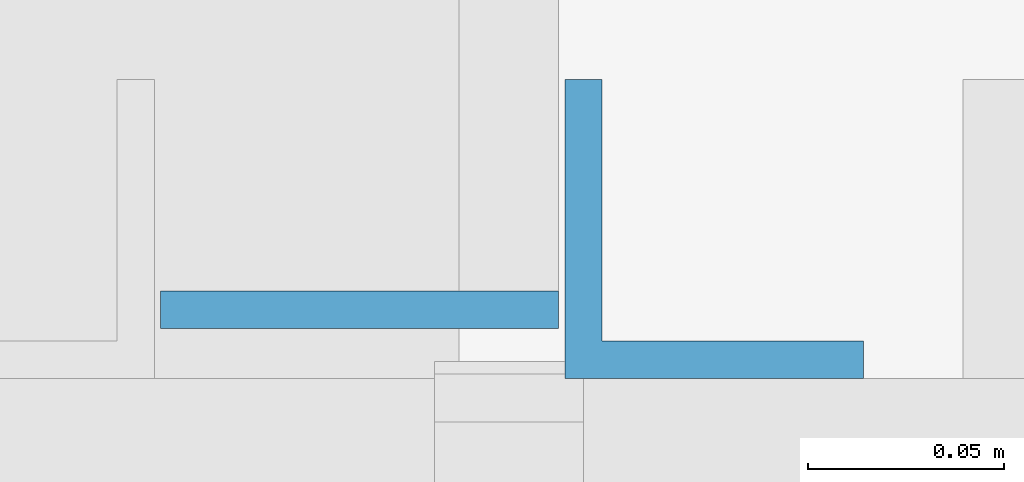
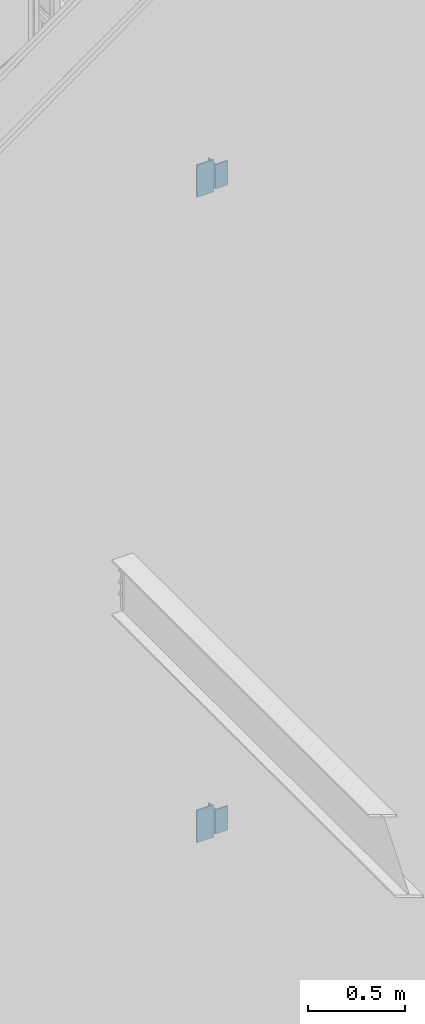
# One storey, part 570 of 1179: 4 columns, 4 elements without a shape of their own.
"""IFC2X3 building model written with IfcOpenShell, lengths in millimetres."""

import ifcopenshell
import ifcopenshell.guid

model = None  # the IFC model being written
_history = None  # IfcOwnerHistory: only IFC2X3 demands one
_inside = {}  # id of a spatial element -> (the spatial element, [elements in it])
_under = {}  # id of a project, library or spatial element -> (it, [spatial elements below it])
_declared = {}  # id of a project -> (the project, [libraries it declares])
_typed = {}  # id of a type object -> (the type object, [elements of that type])
_made_of = {}  # id of a material, layer set ... -> (it, [elements and type objects made of it])


def new_model(schema):
    """Start an empty IFC model of exactly this schema.

    Asked for "IFC4X3", IfcOpenShell would pick the latest addendum, in which some entities
    have other attributes; the version numbers below select the first issue.
    IFC2X3 requires an IfcOwnerHistory on every rooted entity: one is made here for all.
    """
    global model, _history
    if schema == "IFC4X3":
        model = ifcopenshell.file(schema_version=(4, 3, 0, 0))
    else:
        model = ifcopenshell.file(schema=schema)
    _inside.clear()
    _under.clear()
    _declared.clear()
    _typed.clear()
    _made_of.clear()
    _history = None
    if model.schema == "IFC2X3":
        org = make("IfcOrganization", Name="unknown")
        user = make(
            "IfcPersonAndOrganization",
            ThePerson=make("IfcPerson", FamilyName="unknown"),
            TheOrganization=org,
        )
        app = make(
            "IfcApplication",
            ApplicationDeveloper=org,
            Version="unknown",
            ApplicationFullName="unknown",
            ApplicationIdentifier="unknown",
        )
        _history = make(
            "IfcOwnerHistory",
            OwningUser=user,
            OwningApplication=app,
            ChangeAction="ADDED",
            CreationDate=0,
        )
    return model


def make(cls, **values):
    """One entity of the class cls with the attributes given. An attribute that is None is left unset."""
    return model.create_entity(
        cls, **{name: value for name, value in values.items() if value is not None}
    )


def rooted(cls, **values):
    """An entity with a GlobalId (a new one), such as an element, a storey or a relation."""
    return make(cls, GlobalId=ifcopenshell.guid.new(), OwnerHistory=_history, **values)


def si_unit(unit_type, name, prefix=None):
    """IfcSIUnit, for example si_unit("LENGTHUNIT", "METRE", prefix="MILLI")."""
    return make("IfcSIUnit", UnitType=unit_type, Prefix=prefix, Name=name)


def assignment(units):
    """IfcUnitAssignment: the units of a project."""
    return None if units is None else make("IfcUnitAssignment", Units=units)


def point(xyz):
    """IfcCartesianPoint."""
    return None if xyz is None else make("IfcCartesianPoint", Coordinates=xyz)


def direction(xyz):
    """IfcDirection."""
    return None if xyz is None else make("IfcDirection", DirectionRatios=xyz)


def frame(location, z_axis=None, x_axis=None):
    """IfcAxis2Placement3D, a coordinate frame: its origin and axes. An axis left out is left unset."""
    return make(
        "IfcAxis2Placement3D",
        Location=point(location),
        Axis=direction(z_axis),
        RefDirection=direction(x_axis),
    )


def origin_with_axes():
    """The frame at (0, 0, 0) with the z axis (0, 0, 1) and the x axis (1, 0, 0) written out."""
    return frame((0.0, 0.0, 0.0), z_axis=(0.0, 0.0, 1.0), x_axis=(1.0, 0.0, 0.0))


def place(relative_to, where):
    """IfcLocalPlacement: puts the frame where relative to a parent placement (None: the world)."""
    return make(
        "IfcLocalPlacement", PlacementRelTo=relative_to, RelativePlacement=where
    )


def context(
    kind, dimensions, precision=None, world=None, true_north=None, identifier=None
):
    """IfcGeometricRepresentationContext, for example the 3D "Model" context."""
    return make(
        "IfcGeometricRepresentationContext",
        ContextIdentifier=identifier,
        ContextType=kind,
        CoordinateSpaceDimension=dimensions,
        Precision=precision,
        WorldCoordinateSystem=world,
        TrueNorth=true_north,
    )


def subcontext(parent, identifier, kind, view, scale=None):
    """IfcGeometricRepresentationSubContext, for example "Body" below "Model"."""
    return make(
        "IfcGeometricRepresentationSubContext",
        ContextIdentifier=identifier,
        ContextType=kind,
        ParentContext=parent,
        TargetScale=scale,
        TargetView=view,
    )


def project(units=None, contexts=None):
    """IfcProject with its units and contexts."""
    return rooted(
        "IfcProject",
        Name="project",
        RepresentationContexts=contexts,
        UnitsInContext=assignment(units),
    )


def spatial(cls, under=None, at=None, **own):
    """A site, building, storey or space (cls), placed at a placement, below another one or the project."""
    s = rooted(cls, ObjectPlacement=at, **own)
    if under is not None:
        _under.setdefault(under.id(), (under, []))[1].append(s)
    return s


def faces_of(points, faces, orient=None, outer=None):
    """IfcFace entities. A face is a list of loops; a loop is a list of indices into points, from 0.

    orient and outer hold one flag for each loop. By default every Orientation is true, the
    first loop of a face is its IfcFaceOuterBound and the others are IfcFaceBound.
    """
    made = []
    for i, loops in enumerate(faces):
        bounds = []
        for j, loop in enumerate(loops):
            is_outer = j == 0 if outer is None else outer[i][j]
            bounds.append(
                make(
                    "IfcFaceOuterBound" if is_outer else "IfcFaceBound",
                    Bound=make("IfcPolyLoop", Polygon=[points[k] for k in loop]),
                    Orientation=True if orient is None else orient[i][j],
                )
            )
        made.append(make("IfcFace", Bounds=bounds))
    return made


def faceted_brep(points, faces, orient=None, outer=None, voids=None):
    """IfcFacetedBrep: a solid bounded by flat faces; with voids (closed shells), ...WithVoids."""
    shared = [point(p) for p in points]
    hull = make("IfcClosedShell", CfsFaces=faces_of(shared, faces, orient, outer))
    if voids is None:
        return make("IfcFacetedBrep", Outer=hull)
    return make(
        "IfcFacetedBrepWithVoids",
        Outer=hull,
        Voids=[
            make(cls, CfsFaces=faces_of(shared, fs, o, b)) for cls, fs, o, b in voids
        ],
    )


def shape(context_of_items, identifier, shape_type, items):
    """IfcShapeRepresentation: the items that make up one representation, for example the "Body"."""
    return make(
        "IfcShapeRepresentation",
        ContextOfItems=context_of_items,
        RepresentationIdentifier=identifier,
        RepresentationType=shape_type,
        Items=items,
    )


def material(Name=None, Category=None):
    """IfcMaterial."""
    return make("IfcMaterial", Name=Name, Category=Category)


def made_of(thing, what):
    """Note that an element or type object is made of a material, layer set ...; save() writes the relation."""
    if what is not None:
        _made_of.setdefault(what.id(), (what, []))[1].append(thing)
    return thing


def type_object(cls, material=None, **own):
    """A type object (cls), such as IfcWallType, which elements share."""
    return made_of(rooted(cls, **own), material)


def element(
    cls,
    number,
    at=None,
    inside=None,
    cuts=None,
    type_object=None,
    material=None,
    context=None,
    identifier="Body",
    shape_type=None,
    held_by="IfcProductDefinitionShape",
    body=None,
    shapes=None,
    **own,
):
    """One element of the class cls, such as IfcWall. Its Tag is "e" and its number.

    at: its placement. inside: the storey or other place that contains it. cuts: it is an
    opening in that element (IfcRelVoidsElement). A single representation is given by context,
    identifier, shape_type and body (its items); several are given by shapes. held_by: the class
    of the entity that holds the representations. save() writes the other relations.
    """
    e = rooted(cls, Tag="e%d" % number, ObjectPlacement=at, **own)
    if body is not None:
        shapes = [shape(context, identifier, shape_type, body)]
    if shapes is not None:
        e.Representation = make(held_by, Representations=shapes)
    if inside is not None:
        _inside.setdefault(inside.id(), (inside, []))[1].append(e)
    if cuts is not None:
        rooted(
            "IfcRelVoidsElement", RelatingBuildingElement=cuts, RelatedOpeningElement=e
        )
    if type_object is not None:
        _typed.setdefault(type_object.id(), (type_object, []))[1].append(e)
    return made_of(e, material)


def aggregate(whole, parts):
    """IfcRelAggregates: a whole, such as a stair, and the parts it consists of."""
    return rooted("IfcRelAggregates", RelatingObject=whole, RelatedObjects=parts)


def save(model, path):
    """Write the relations noted so far, then the file.

    IfcRelAggregates (storeys below a building ...), IfcRelContainedInSpatialStructure (elements
    in a storey), IfcRelDefinesByType, IfcRelAssociatesMaterial and IfcRelDeclares: one each for
    every whole, place, type object, material and project.
    """
    for whole, parts in _under.values():
        aggregate(whole, parts)
    for where, things in _inside.values():
        rooted(
            "IfcRelContainedInSpatialStructure",
            RelatedElements=things,
            RelatingStructure=where,
        )
    for kind, things in _typed.values():
        rooted("IfcRelDefinesByType", RelatedObjects=things, RelatingType=kind)
    for what, things in _made_of.values():
        rooted("IfcRelAssociatesMaterial", RelatedObjects=things, RelatingMaterial=what)
    for by, libraries in _declared.values():
        rooted("IfcRelDeclares", RelatingContext=by, RelatedDefinitions=libraries)
    model.write(path)


model = new_model("IFC2X3")

# Units and contexts
model_context = context("Model", 3, precision=1e-05, world=origin_with_axes())
body_context = subcontext(model_context, "Body", "Model", "MODEL_VIEW")
ifc_project = project(units=[si_unit("LENGTHUNIT", "METRE", prefix="MILLI"), si_unit("AREAUNIT", "SQUARE_METRE"), si_unit("VOLUMEUNIT", "CUBIC_METRE"), si_unit("MASSUNIT", "GRAM", prefix="KILO"), si_unit("TIMEUNIT", "SECOND"), si_unit("PLANEANGLEUNIT", "RADIAN"), si_unit("SOLIDANGLEUNIT", "STERADIAN"), si_unit("THERMODYNAMICTEMPERATUREUNIT", "DEGREE_CELSIUS"), si_unit("LUMINOUSINTENSITYUNIT", "LUMEN")], contexts=[model_context])

# Site, building, storey
site_placement = place(None, origin_with_axes())
site = spatial("IfcSite", under=ifc_project, at=site_placement, CompositionType="ELEMENT")
building_placement = place(site_placement, origin_with_axes())
building = spatial("IfcBuilding", under=site, at=building_placement, Name="Undefined", CompositionType="ELEMENT")
storey_placement = place(building_placement, origin_with_axes())
storey = spatial("IfcBuildingStorey", under=building, at=storey_placement, Name="Undefined", CompositionType="ELEMENT", Elevation=0.0)

# Assembly, column
assembly_1_placement = place(storey_placement, origin_with_axes())
assembly_1 = element("IfcElementAssembly", 1, at=assembly_1_placement, inside=storey, Name="BEAM", AssemblyPlace="NOTDEFINED", PredefinedType="RIGID_FRAME")
ifc_material = material(Name="STEEL/A36")
column_type_1 = type_object("IfcColumnType", PredefinedType="NOTDEFINED")
column_1_placement = place(assembly_1_placement, frame((23018.7499999835, 38225.4124999754, 5934.67000099707), z_axis=(1.0, 0.0, 0.0), x_axis=(0.0, 0.0, 1.0)))
column_1 = element("IfcColumn", 2, at=column_1_placement, type_object=column_type_1, material=ifc_material, Name="PLATE", context=body_context, shape_type="Brep", body=[
    faceted_brep([(0.0, 4.76249999999982, -50.7999999999993), (0.0, 4.76249999999982, 50.7999999999993), (203.2, 4.76249999999709, 50.7999999999993), (203.2, 4.76249999999709, -50.7999999999993), (0.0, -4.76249999999982, 50.7999999999993), (203.2, -4.76249999999709, 50.7999999999993), (0.0, -4.76249999999982, -50.7999999999993), (203.2, -4.76249999999709, -50.7999999999993)], [[[0, 1, 2, 3]], [[1, 4, 5, 2]], [[4, 6, 7, 5]], [[6, 0, 3, 7]], [[5, 7, 3, 2]], [[6, 4, 1, 0]]]),
])
aggregate(assembly_1, [column_1])

assembly_2_placement = place(storey_placement, origin_with_axes())
assembly_2 = element("IfcElementAssembly", 3, at=assembly_2_placement, inside=storey, Name="BEAM", AssemblyPlace="NOTDEFINED", PredefinedType="RIGID_FRAME")
column_2_placement = place(assembly_2_placement, frame((23018.7500003381, 38225.4124999748, 1861.145312), z_axis=(1.0, 0.0, 0.0), x_axis=(0.0, 0.0, 1.0)))
column_2 = element("IfcColumn", 4, at=column_2_placement, type_object=column_type_1, material=ifc_material, Name="PLATE", context=body_context, shape_type="Brep", body=[
    faceted_brep([(0.0, 4.76249999999982, -50.7999999999993), (0.0, 4.76249999999982, 50.7999999999993), (203.2, 4.76249999999709, 50.7999999999993), (203.2, 4.76249999999709, -50.7999999999993), (0.0, -4.76249999999982, 50.7999999999993), (203.2, -4.76249999999709, 50.7999999999993), (0.0, -4.76249999999982, -50.7999999999993), (203.2, -4.76249999999709, -50.7999999999993)], [[[0, 1, 2, 3]], [[1, 4, 5, 2]], [[4, 6, 7, 5]], [[6, 0, 3, 7]], [[5, 7, 3, 2]], [[6, 4, 1, 0]]]),
])
aggregate(assembly_2, [column_2])

assembly_3_placement = place(storey_placement, origin_with_axes())
assembly_3 = element("IfcElementAssembly", 5, at=assembly_3_placement, inside=storey, Name="STAIR", AssemblyPlace="NOTDEFINED", PredefinedType="RIGID_FRAME")
column_type_2 = type_object("IfcColumnType", Name="L3X3X3/8", PredefinedType="NOTDEFINED")
column_3_placement = place(assembly_3_placement, frame((23109.2374999835, 38246.0499999749, 5960.07000099707), z_axis=(1.0, 0.0, 0.0), x_axis=(0.0, 0.0, 1.0)))
column_3 = element("IfcColumn", 6, at=column_3_placement, type_object=column_type_2, material=ifc_material, Name="ANGLE", ObjectType="L3X3X3/8", context=body_context, shape_type="Brep", body=[
    faceted_brep([(0.0, 38.0999999999985, -38.0999999999999), (0.0, 38.0999999999985, 38.0999999999999), (152.400000000001, 38.0999999999985, 38.0999999999999), (152.400000000001, 38.0999999999985, -38.0999999999999), (0.0, 28.5750000000007, 38.0999999999999), (152.400000000001, 28.5750000000007, 38.0999999999999), (0.0, 28.5750000000007, -28.575), (152.400000000001, 28.5750000000007, -28.575), (0.0, -38.0999999999985, -28.575), (152.400000000001, -38.0999999999985, -28.575), (0.0, -38.0999999999985, -38.0999999999999), (152.400000000001, -38.0999999999985, -38.0999999999999)], [[[0, 1, 2, 3]], [[1, 4, 5, 2]], [[4, 6, 7, 5]], [[6, 8, 9, 7]], [[8, 10, 11, 9]], [[10, 0, 3, 11]], [[5, 7, 9, 11, 3, 2]], [[10, 8, 6, 4, 1, 0]]]),
])
aggregate(assembly_3, [column_3])

assembly_4_placement = place(storey_placement, origin_with_axes())
assembly_4 = element("IfcElementAssembly", 7, at=assembly_4_placement, inside=storey, Name="STAIR", AssemblyPlace="NOTDEFINED", PredefinedType="RIGID_FRAME")
column_4_placement = place(assembly_4_placement, frame((23109.2375003381, 38246.0499999267, 1886.545312), z_axis=(1.0, 0.0, 0.0), x_axis=(0.0, 0.0, 1.0)))
column_4 = element("IfcColumn", 8, at=column_4_placement, type_object=column_type_2, material=ifc_material, Name="ANGLE", ObjectType="L3X3X3/8", context=body_context, shape_type="Brep", body=[
    faceted_brep([(0.0, 38.0999999999985, -38.0999999999999), (0.0, 38.0999999999985, 38.0999999999999), (152.400000000001, 38.0999999999985, 38.0999999999999), (152.400000000001, 38.0999999999985, -38.0999999999999), (0.0, 28.5750000000007, 38.0999999999999), (152.400000000001, 28.5750000000007, 38.0999999999999), (0.0, 28.5750000000007, -28.575), (152.400000000001, 28.5750000000007, -28.575), (0.0, -38.0999999999985, -28.575), (152.400000000001, -38.0999999999985, -28.575), (0.0, -38.0999999999985, -38.0999999999999), (152.400000000001, -38.0999999999985, -38.0999999999999)], [[[0, 1, 2, 3]], [[1, 4, 5, 2]], [[4, 6, 7, 5]], [[6, 8, 9, 7]], [[8, 10, 11, 9]], [[10, 0, 3, 11]], [[5, 7, 9, 11, 3, 2]], [[10, 8, 6, 4, 1, 0]]]),
])
aggregate(assembly_4, [column_4])

save(model, "model.ifc")
